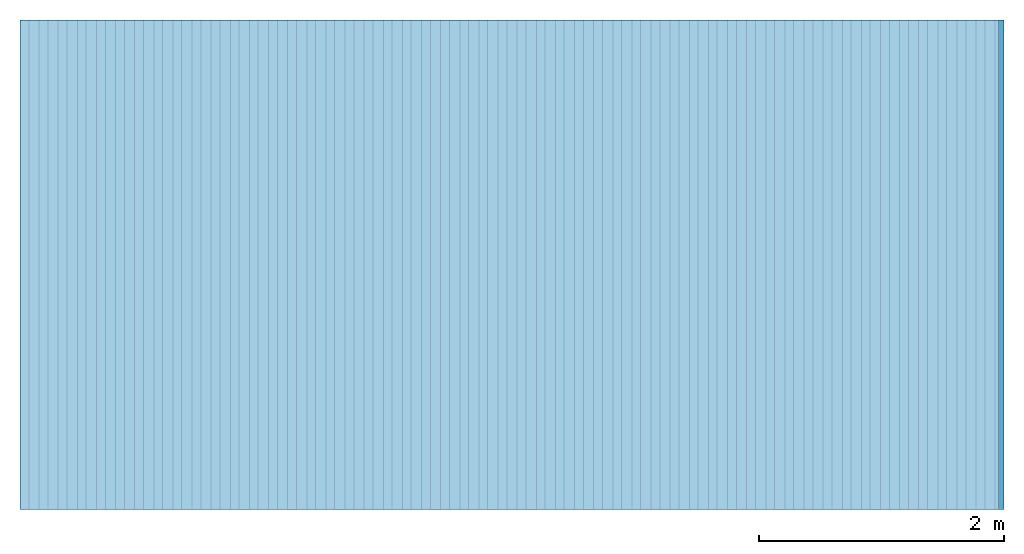
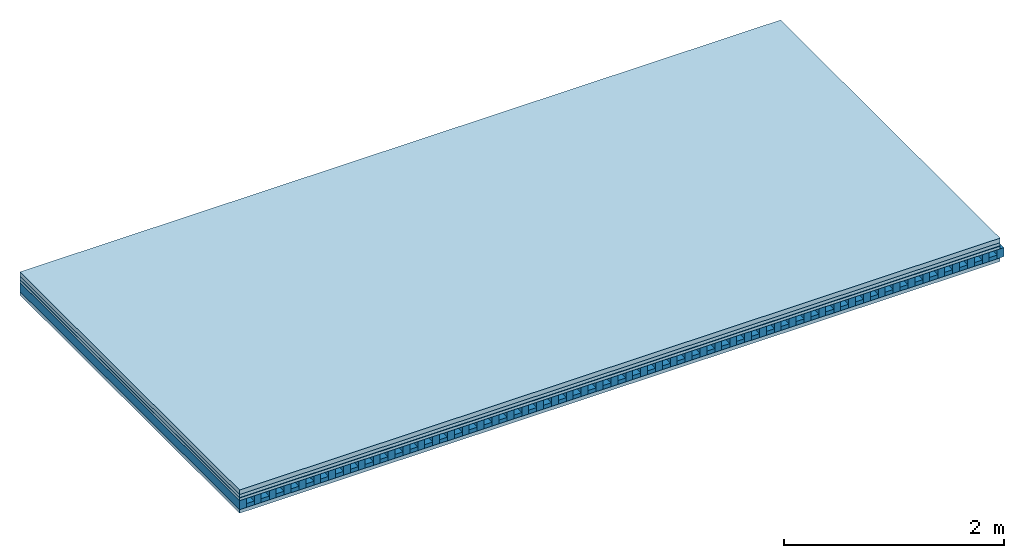
# One storey: 5 plates, 2 members, 1 element without a shape of its own.
"""IFC4 building model written with IfcOpenShell, lengths in metres."""

from ifc_helpers import new_model, si_unit, derived_unit, direction, frame, frame_2d, origin, origin_with_axes, place, context, project, spatial, rectangle, extrude, material, layer, layer_set, type_object, element, aggregate, save


model = new_model("IFC4")

# Units and contexts
plan_context = context("Plan", 3, precision=1e-05, world=origin(), true_north=direction((0.0, 1.0)))
model_context = context("Model", 3, precision=1e-05, world=origin(), true_north=direction((0.0, 1.0)))
ifc_project = project(units=[si_unit("LENGTHUNIT", "METRE"), derived_unit("SOUNDPRESSUREUNIT", [(si_unit("PRESSUREUNIT", "PASCAL", prefix="MICRO"), 0)]), si_unit("ENERGYUNIT", "JOULE", prefix="MEGA"), si_unit("MASSUNIT", "GRAM", prefix="KILO"), derived_unit("THERMALTRANSMITTANCEUNIT", [(si_unit("POWERUNIT", "WATT"), 1), (si_unit("AREAUNIT", "SQUARE_METRE"), -1), (si_unit("THERMODYNAMICTEMPERATUREUNIT", "KELVIN"), -1)]), derived_unit("AREADENSITYUNIT", [(si_unit("MASSUNIT", "GRAM", prefix="KILO"), 1), (si_unit("AREAUNIT", "SQUARE_METRE"), -1)]), derived_unit("USERDEFINED", [(si_unit("ENERGYUNIT", "JOULE", prefix="MEGA"), 1), (si_unit("AREAUNIT", "SQUARE_METRE"), -1)])], contexts=[plan_context, model_context])

# Site, building, storey
site = spatial("IfcSite", under=ifc_project)
building_placement = place(None, origin())
building = spatial("IfcBuilding", under=site, at=building_placement)
storey_placement = place(building_placement, origin())
storey = spatial("IfcBuildingStorey", under=building, at=storey_placement)

# Slab, members, plates
ifc_material_1 = material(Name="Cement screed", Category="04.006")
ifc_layer_1 = layer(ifc_material_1, 0.05, Name="On-material")
ifc_material_2 = material(Name="EP1, 35mm")
ifc_layer_2 = layer(ifc_material_2, 0.035, Name="Impact sound insulation")
ifc_material_3 = material(Name="Step 4mm", Category="10.009")
ifc_layer_3 = layer(ifc_material_3, 0.004, Name="Additional insulation")
ifc_material_4 = material()
ifc_layer_4 = layer(ifc_material_4, 0.03, Name="Sub-floor")
ifc_material_5 = material(Name="Rigid, of the art")
ifc_layer_5 = layer(ifc_material_5, 0.0, Name="Bond")
ifc_layer_6 = layer(None, 0.1, Name="Supporting structure")
ifc_layer_7 = layer(ifc_material_5, 0.0, Name="Bond")
ifc_material_6 = material(Name="panel on the underside HBF 40mm (20+20mm)", Category="07.001")
ifc_layer_8 = layer(ifc_material_6, 0.04, Name="Lower layer 1")
ifc_layer_set = layer_set([ifc_layer_1, ifc_layer_2, ifc_layer_3, ifc_layer_4, ifc_layer_5, ifc_layer_6, ifc_layer_7, ifc_layer_8])
slab_type = type_object("IfcSlabType", Name="A0086", PredefinedType="NOTDEFINED", material=ifc_layer_set)
slab_placement = place(None, frame((0.0, 0.0, 0.0), z_axis=(0.0, 0.0, -1.0), x_axis=(1.0, 0.0, 0.0)))
slab = element("IfcSlab", 1, at=slab_placement, inside=storey, type_object=slab_type, material=ifc_layer_set, Name="Slab #1")
ifc_material_7 = material(Name="Block Q4")
member_1_placement = place(slab_placement, origin())
member_1 = element("IfcMember", 2, at=member_1_placement, material=ifc_material_7, Name="Supporting structure", context=plan_context, shape_type="SweptSolid", body=[
    extrude(rectangle(XDim=0.071666666666667, YDim=0.1, at=frame_2d((0.0358333333333335, 0.05), x_axis=(1.0, 0.0))), frame((0.0, 4.0, 0.119), z_axis=(0.0, -1.0, 0.0), x_axis=(1.0, 0.0, 0.0)), (0.0, 0.0, 1.0), 4.0),
    extrude(rectangle(XDim=0.071666666666667, YDim=0.1, at=frame_2d((0.0358333333333335, 0.05), x_axis=(1.0, 0.0))), frame((0.15625, 4.0, 0.119), z_axis=(0.0, -1.0, 0.0), x_axis=(1.0, 0.0, 0.0)), (0.0, 0.0, 1.0), 4.0),
    extrude(rectangle(XDim=0.071666666666667, YDim=0.1, at=frame_2d((0.0358333333333335, 0.05), x_axis=(1.0, 0.0))), frame((0.3125, 4.0, 0.119), z_axis=(0.0, -1.0, 0.0), x_axis=(1.0, 0.0, 0.0)), (0.0, 0.0, 1.0), 4.0),
    extrude(rectangle(XDim=0.071666666666667, YDim=0.1, at=frame_2d((0.0358333333333335, 0.05), x_axis=(1.0, 0.0))), frame((0.46875, 4.0, 0.119), z_axis=(0.0, -1.0, 0.0), x_axis=(1.0, 0.0, 0.0)), (0.0, 0.0, 1.0), 4.0),
    extrude(rectangle(XDim=0.071666666666667, YDim=0.1, at=frame_2d((0.0358333333333335, 0.05), x_axis=(1.0, 0.0))), frame((0.625, 4.0, 0.119), z_axis=(0.0, -1.0, 0.0), x_axis=(1.0, 0.0, 0.0)), (0.0, 0.0, 1.0), 4.0),
    extrude(rectangle(XDim=0.071666666666667, YDim=0.1, at=frame_2d((0.0358333333333335, 0.05), x_axis=(1.0, 0.0))), frame((0.78125, 4.0, 0.119), z_axis=(0.0, -1.0, 0.0), x_axis=(1.0, 0.0, 0.0)), (0.0, 0.0, 1.0), 4.0),
    extrude(rectangle(XDim=0.071666666666667, YDim=0.1, at=frame_2d((0.0358333333333335, 0.05), x_axis=(1.0, 0.0))), frame((0.9375, 4.0, 0.119), z_axis=(0.0, -1.0, 0.0), x_axis=(1.0, 0.0, 0.0)), (0.0, 0.0, 1.0), 4.0),
    extrude(rectangle(XDim=0.071666666666667, YDim=0.1, at=frame_2d((0.0358333333333335, 0.05), x_axis=(1.0, 0.0))), frame((1.09375, 4.0, 0.119), z_axis=(0.0, -1.0, 0.0), x_axis=(1.0, 0.0, 0.0)), (0.0, 0.0, 1.0), 4.0),
    extrude(rectangle(XDim=0.071666666666667, YDim=0.1, at=frame_2d((0.0358333333333335, 0.05), x_axis=(1.0, 0.0))), frame((1.25, 4.0, 0.119), z_axis=(0.0, -1.0, 0.0), x_axis=(1.0, 0.0, 0.0)), (0.0, 0.0, 1.0), 4.0),
    extrude(rectangle(XDim=0.071666666666667, YDim=0.1, at=frame_2d((0.0358333333333335, 0.05), x_axis=(1.0, 0.0))), frame((1.40625, 4.0, 0.119), z_axis=(0.0, -1.0, 0.0), x_axis=(1.0, 0.0, 0.0)), (0.0, 0.0, 1.0), 4.0),
    extrude(rectangle(XDim=0.071666666666667, YDim=0.1, at=frame_2d((0.0358333333333335, 0.05), x_axis=(1.0, 0.0))), frame((1.5625, 4.0, 0.119), z_axis=(0.0, -1.0, 0.0), x_axis=(1.0, 0.0, 0.0)), (0.0, 0.0, 1.0), 4.0),
    extrude(rectangle(XDim=0.071666666666667, YDim=0.1, at=frame_2d((0.0358333333333335, 0.05), x_axis=(1.0, 0.0))), frame((1.71875, 4.0, 0.119), z_axis=(0.0, -1.0, 0.0), x_axis=(1.0, 0.0, 0.0)), (0.0, 0.0, 1.0), 4.0),
    extrude(rectangle(XDim=0.071666666666667, YDim=0.1, at=frame_2d((0.0358333333333335, 0.05), x_axis=(1.0, 0.0))), frame((1.875, 4.0, 0.119), z_axis=(0.0, -1.0, 0.0), x_axis=(1.0, 0.0, 0.0)), (0.0, 0.0, 1.0), 4.0),
    extrude(rectangle(XDim=0.071666666666667, YDim=0.1, at=frame_2d((0.0358333333333335, 0.05), x_axis=(1.0, 0.0))), frame((2.03125, 4.0, 0.119), z_axis=(0.0, -1.0, 0.0), x_axis=(1.0, 0.0, 0.0)), (0.0, 0.0, 1.0), 4.0),
    extrude(rectangle(XDim=0.071666666666667, YDim=0.1, at=frame_2d((0.0358333333333335, 0.05), x_axis=(1.0, 0.0))), frame((2.1875, 4.0, 0.119), z_axis=(0.0, -1.0, 0.0), x_axis=(1.0, 0.0, 0.0)), (0.0, 0.0, 1.0), 4.0),
    extrude(rectangle(XDim=0.071666666666667, YDim=0.1, at=frame_2d((0.0358333333333335, 0.05), x_axis=(1.0, 0.0))), frame((2.34375, 4.0, 0.119), z_axis=(0.0, -1.0, 0.0), x_axis=(1.0, 0.0, 0.0)), (0.0, 0.0, 1.0), 4.0),
    extrude(rectangle(XDim=0.071666666666667, YDim=0.1, at=frame_2d((0.0358333333333335, 0.05), x_axis=(1.0, 0.0))), frame((2.5, 4.0, 0.119), z_axis=(0.0, -1.0, 0.0), x_axis=(1.0, 0.0, 0.0)), (0.0, 0.0, 1.0), 4.0),
    extrude(rectangle(XDim=0.071666666666667, YDim=0.1, at=frame_2d((0.0358333333333335, 0.05), x_axis=(1.0, 0.0))), frame((2.65625, 4.0, 0.119), z_axis=(0.0, -1.0, 0.0), x_axis=(1.0, 0.0, 0.0)), (0.0, 0.0, 1.0), 4.0),
    extrude(rectangle(XDim=0.071666666666667, YDim=0.1, at=frame_2d((0.0358333333333335, 0.05), x_axis=(1.0, 0.0))), frame((2.8125, 4.0, 0.119), z_axis=(0.0, -1.0, 0.0), x_axis=(1.0, 0.0, 0.0)), (0.0, 0.0, 1.0), 4.0),
    extrude(rectangle(XDim=0.071666666666667, YDim=0.1, at=frame_2d((0.0358333333333335, 0.05), x_axis=(1.0, 0.0))), frame((2.96875, 4.0, 0.119), z_axis=(0.0, -1.0, 0.0), x_axis=(1.0, 0.0, 0.0)), (0.0, 0.0, 1.0), 4.0),
    extrude(rectangle(XDim=0.071666666666667, YDim=0.1, at=frame_2d((0.0358333333333335, 0.05), x_axis=(1.0, 0.0))), frame((3.125, 4.0, 0.119), z_axis=(0.0, -1.0, 0.0), x_axis=(1.0, 0.0, 0.0)), (0.0, 0.0, 1.0), 4.0),
    extrude(rectangle(XDim=0.071666666666667, YDim=0.1, at=frame_2d((0.0358333333333335, 0.05), x_axis=(1.0, 0.0))), frame((3.28125, 4.0, 0.119), z_axis=(0.0, -1.0, 0.0), x_axis=(1.0, 0.0, 0.0)), (0.0, 0.0, 1.0), 4.0),
    extrude(rectangle(XDim=0.071666666666667, YDim=0.1, at=frame_2d((0.0358333333333335, 0.05), x_axis=(1.0, 0.0))), frame((3.4375, 4.0, 0.119), z_axis=(0.0, -1.0, 0.0), x_axis=(1.0, 0.0, 0.0)), (0.0, 0.0, 1.0), 4.0),
    extrude(rectangle(XDim=0.071666666666667, YDim=0.1, at=frame_2d((0.0358333333333335, 0.05), x_axis=(1.0, 0.0))), frame((3.59375, 4.0, 0.119), z_axis=(0.0, -1.0, 0.0), x_axis=(1.0, 0.0, 0.0)), (0.0, 0.0, 1.0), 4.0),
    extrude(rectangle(XDim=0.071666666666667, YDim=0.1, at=frame_2d((0.0358333333333335, 0.05), x_axis=(1.0, 0.0))), frame((3.75, 4.0, 0.119), z_axis=(0.0, -1.0, 0.0), x_axis=(1.0, 0.0, 0.0)), (0.0, 0.0, 1.0), 4.0),
    extrude(rectangle(XDim=0.071666666666667, YDim=0.1, at=frame_2d((0.0358333333333335, 0.05), x_axis=(1.0, 0.0))), frame((3.90625, 4.0, 0.119), z_axis=(0.0, -1.0, 0.0), x_axis=(1.0, 0.0, 0.0)), (0.0, 0.0, 1.0), 4.0),
    extrude(rectangle(XDim=0.071666666666667, YDim=0.1, at=frame_2d((0.0358333333333335, 0.05), x_axis=(1.0, 0.0))), frame((4.0625, 4.0, 0.119), z_axis=(0.0, -1.0, 0.0), x_axis=(1.0, 0.0, 0.0)), (0.0, 0.0, 1.0), 4.0),
    extrude(rectangle(XDim=0.071666666666667, YDim=0.1, at=frame_2d((0.0358333333333335, 0.05), x_axis=(1.0, 0.0))), frame((4.21875, 4.0, 0.119), z_axis=(0.0, -1.0, 0.0), x_axis=(1.0, 0.0, 0.0)), (0.0, 0.0, 1.0), 4.0),
    extrude(rectangle(XDim=0.071666666666667, YDim=0.1, at=frame_2d((0.0358333333333335, 0.05), x_axis=(1.0, 0.0))), frame((4.375, 4.0, 0.119), z_axis=(0.0, -1.0, 0.0), x_axis=(1.0, 0.0, 0.0)), (0.0, 0.0, 1.0), 4.0),
    extrude(rectangle(XDim=0.071666666666667, YDim=0.1, at=frame_2d((0.0358333333333335, 0.05), x_axis=(1.0, 0.0))), frame((4.53125, 4.0, 0.119), z_axis=(0.0, -1.0, 0.0), x_axis=(1.0, 0.0, 0.0)), (0.0, 0.0, 1.0), 4.0),
    extrude(rectangle(XDim=0.071666666666667, YDim=0.1, at=frame_2d((0.0358333333333335, 0.05), x_axis=(1.0, 0.0))), frame((4.6875, 4.0, 0.119), z_axis=(0.0, -1.0, 0.0), x_axis=(1.0, 0.0, 0.0)), (0.0, 0.0, 1.0), 4.0),
    extrude(rectangle(XDim=0.071666666666667, YDim=0.1, at=frame_2d((0.0358333333333335, 0.05), x_axis=(1.0, 0.0))), frame((4.84375, 4.0, 0.119), z_axis=(0.0, -1.0, 0.0), x_axis=(1.0, 0.0, 0.0)), (0.0, 0.0, 1.0), 4.0),
    extrude(rectangle(XDim=0.071666666666667, YDim=0.1, at=frame_2d((0.0358333333333335, 0.05), x_axis=(1.0, 0.0))), frame((5.0, 4.0, 0.119), z_axis=(0.0, -1.0, 0.0), x_axis=(1.0, 0.0, 0.0)), (0.0, 0.0, 1.0), 4.0),
    extrude(rectangle(XDim=0.071666666666667, YDim=0.1, at=frame_2d((0.0358333333333335, 0.05), x_axis=(1.0, 0.0))), frame((5.15625, 4.0, 0.119), z_axis=(0.0, -1.0, 0.0), x_axis=(1.0, 0.0, 0.0)), (0.0, 0.0, 1.0), 4.0),
    extrude(rectangle(XDim=0.071666666666667, YDim=0.1, at=frame_2d((0.0358333333333335, 0.05), x_axis=(1.0, 0.0))), frame((5.3125, 4.0, 0.119), z_axis=(0.0, -1.0, 0.0), x_axis=(1.0, 0.0, 0.0)), (0.0, 0.0, 1.0), 4.0),
    extrude(rectangle(XDim=0.071666666666667, YDim=0.1, at=frame_2d((0.0358333333333335, 0.05), x_axis=(1.0, 0.0))), frame((5.46875, 4.0, 0.119), z_axis=(0.0, -1.0, 0.0), x_axis=(1.0, 0.0, 0.0)), (0.0, 0.0, 1.0), 4.0),
    extrude(rectangle(XDim=0.071666666666667, YDim=0.1, at=frame_2d((0.0358333333333335, 0.05), x_axis=(1.0, 0.0))), frame((5.625, 4.0, 0.119), z_axis=(0.0, -1.0, 0.0), x_axis=(1.0, 0.0, 0.0)), (0.0, 0.0, 1.0), 4.0),
    extrude(rectangle(XDim=0.071666666666667, YDim=0.1, at=frame_2d((0.0358333333333335, 0.05), x_axis=(1.0, 0.0))), frame((5.78125, 4.0, 0.119), z_axis=(0.0, -1.0, 0.0), x_axis=(1.0, 0.0, 0.0)), (0.0, 0.0, 1.0), 4.0),
    extrude(rectangle(XDim=0.071666666666667, YDim=0.1, at=frame_2d((0.0358333333333335, 0.05), x_axis=(1.0, 0.0))), frame((5.9375, 4.0, 0.119), z_axis=(0.0, -1.0, 0.0), x_axis=(1.0, 0.0, 0.0)), (0.0, 0.0, 1.0), 4.0),
    extrude(rectangle(XDim=0.071666666666667, YDim=0.1, at=frame_2d((0.0358333333333335, 0.05), x_axis=(1.0, 0.0))), frame((6.09375, 4.0, 0.119), z_axis=(0.0, -1.0, 0.0), x_axis=(1.0, 0.0, 0.0)), (0.0, 0.0, 1.0), 4.0),
    extrude(rectangle(XDim=0.071666666666667, YDim=0.1, at=frame_2d((0.0358333333333335, 0.05), x_axis=(1.0, 0.0))), frame((6.25, 4.0, 0.119), z_axis=(0.0, -1.0, 0.0), x_axis=(1.0, 0.0, 0.0)), (0.0, 0.0, 1.0), 4.0),
    extrude(rectangle(XDim=0.071666666666667, YDim=0.1, at=frame_2d((0.0358333333333335, 0.05), x_axis=(1.0, 0.0))), frame((6.40625, 4.0, 0.119), z_axis=(0.0, -1.0, 0.0), x_axis=(1.0, 0.0, 0.0)), (0.0, 0.0, 1.0), 4.0),
    extrude(rectangle(XDim=0.071666666666667, YDim=0.1, at=frame_2d((0.0358333333333335, 0.05), x_axis=(1.0, 0.0))), frame((6.5625, 4.0, 0.119), z_axis=(0.0, -1.0, 0.0), x_axis=(1.0, 0.0, 0.0)), (0.0, 0.0, 1.0), 4.0),
    extrude(rectangle(XDim=0.071666666666667, YDim=0.1, at=frame_2d((0.0358333333333335, 0.05), x_axis=(1.0, 0.0))), frame((6.71875, 4.0, 0.119), z_axis=(0.0, -1.0, 0.0), x_axis=(1.0, 0.0, 0.0)), (0.0, 0.0, 1.0), 4.0),
    extrude(rectangle(XDim=0.071666666666667, YDim=0.1, at=frame_2d((0.0358333333333335, 0.05), x_axis=(1.0, 0.0))), frame((6.875, 4.0, 0.119), z_axis=(0.0, -1.0, 0.0), x_axis=(1.0, 0.0, 0.0)), (0.0, 0.0, 1.0), 4.0),
    extrude(rectangle(XDim=0.071666666666667, YDim=0.1, at=frame_2d((0.0358333333333335, 0.05), x_axis=(1.0, 0.0))), frame((7.03125, 4.0, 0.119), z_axis=(0.0, -1.0, 0.0), x_axis=(1.0, 0.0, 0.0)), (0.0, 0.0, 1.0), 4.0),
    extrude(rectangle(XDim=0.071666666666667, YDim=0.1, at=frame_2d((0.0358333333333335, 0.05), x_axis=(1.0, 0.0))), frame((7.1875, 4.0, 0.119), z_axis=(0.0, -1.0, 0.0), x_axis=(1.0, 0.0, 0.0)), (0.0, 0.0, 1.0), 4.0),
    extrude(rectangle(XDim=0.071666666666667, YDim=0.1, at=frame_2d((0.0358333333333335, 0.05), x_axis=(1.0, 0.0))), frame((7.34375, 4.0, 0.119), z_axis=(0.0, -1.0, 0.0), x_axis=(1.0, 0.0, 0.0)), (0.0, 0.0, 1.0), 4.0),
    extrude(rectangle(XDim=0.071666666666667, YDim=0.1, at=frame_2d((0.0358333333333335, 0.05), x_axis=(1.0, 0.0))), frame((7.5, 4.0, 0.119), z_axis=(0.0, -1.0, 0.0), x_axis=(1.0, 0.0, 0.0)), (0.0, 0.0, 1.0), 4.0),
    extrude(rectangle(XDim=0.071666666666667, YDim=0.1, at=frame_2d((0.0358333333333335, 0.05), x_axis=(1.0, 0.0))), frame((7.65625, 4.0, 0.119), z_axis=(0.0, -1.0, 0.0), x_axis=(1.0, 0.0, 0.0)), (0.0, 0.0, 1.0), 4.0),
    extrude(rectangle(XDim=0.071666666666667, YDim=0.1, at=frame_2d((0.0358333333333335, 0.05), x_axis=(1.0, 0.0))), frame((7.8125, 4.0, 0.119), z_axis=(0.0, -1.0, 0.0), x_axis=(1.0, 0.0, 0.0)), (0.0, 0.0, 1.0), 4.0),
    extrude(rectangle(XDim=0.071666666666667, YDim=0.1, at=frame_2d((0.0358333333333335, 0.05), x_axis=(1.0, 0.0))), frame((7.96875, 4.0, 0.119), z_axis=(0.0, -1.0, 0.0), x_axis=(1.0, 0.0, 0.0)), (0.0, 0.0, 1.0), 4.0),
])
ifc_material_8 = material()
member_2_placement = place(slab_placement, origin())
member_2 = element("IfcMember", 3, at=member_2_placement, material=ifc_material_8, Name="in supporting structure", context=plan_context, shape_type="SweptSolid", body=[
    extrude(rectangle(XDim=0.084583333333333, YDim=0.042, at=frame_2d((0.0422916666666665, 0.021), x_axis=(1.0, 0.0))), frame((0.071666666666667, 4.0, 0.177), z_axis=(0.0, -1.0, 0.0), x_axis=(1.0, 0.0, 0.0)), (0.0, 0.0, 1.0), 4.0),
    extrude(rectangle(XDim=0.084583333333333, YDim=0.042, at=frame_2d((0.0422916666666665, 0.021), x_axis=(1.0, 0.0))), frame((0.227916666666667, 4.0, 0.177), z_axis=(0.0, -1.0, 0.0), x_axis=(1.0, 0.0, 0.0)), (0.0, 0.0, 1.0), 4.0),
    extrude(rectangle(XDim=0.084583333333333, YDim=0.042, at=frame_2d((0.0422916666666665, 0.021), x_axis=(1.0, 0.0))), frame((0.384166666666667, 4.0, 0.177), z_axis=(0.0, -1.0, 0.0), x_axis=(1.0, 0.0, 0.0)), (0.0, 0.0, 1.0), 4.0),
    extrude(rectangle(XDim=0.084583333333333, YDim=0.042, at=frame_2d((0.0422916666666665, 0.021), x_axis=(1.0, 0.0))), frame((0.540416666666667, 4.0, 0.177), z_axis=(0.0, -1.0, 0.0), x_axis=(1.0, 0.0, 0.0)), (0.0, 0.0, 1.0), 4.0),
    extrude(rectangle(XDim=0.084583333333333, YDim=0.042, at=frame_2d((0.0422916666666665, 0.021), x_axis=(1.0, 0.0))), frame((0.696666666666667, 4.0, 0.177), z_axis=(0.0, -1.0, 0.0), x_axis=(1.0, 0.0, 0.0)), (0.0, 0.0, 1.0), 4.0),
    extrude(rectangle(XDim=0.084583333333333, YDim=0.042, at=frame_2d((0.0422916666666665, 0.021), x_axis=(1.0, 0.0))), frame((0.852916666666667, 4.0, 0.177), z_axis=(0.0, -1.0, 0.0), x_axis=(1.0, 0.0, 0.0)), (0.0, 0.0, 1.0), 4.0),
    extrude(rectangle(XDim=0.084583333333333, YDim=0.042, at=frame_2d((0.0422916666666665, 0.021), x_axis=(1.0, 0.0))), frame((1.00916666666667, 4.0, 0.177), z_axis=(0.0, -1.0, 0.0), x_axis=(1.0, 0.0, 0.0)), (0.0, 0.0, 1.0), 4.0),
    extrude(rectangle(XDim=0.084583333333333, YDim=0.042, at=frame_2d((0.0422916666666665, 0.021), x_axis=(1.0, 0.0))), frame((1.16541666666667, 4.0, 0.177), z_axis=(0.0, -1.0, 0.0), x_axis=(1.0, 0.0, 0.0)), (0.0, 0.0, 1.0), 4.0),
    extrude(rectangle(XDim=0.084583333333333, YDim=0.042, at=frame_2d((0.0422916666666665, 0.021), x_axis=(1.0, 0.0))), frame((1.32166666666667, 4.0, 0.177), z_axis=(0.0, -1.0, 0.0), x_axis=(1.0, 0.0, 0.0)), (0.0, 0.0, 1.0), 4.0),
    extrude(rectangle(XDim=0.084583333333333, YDim=0.042, at=frame_2d((0.0422916666666665, 0.021), x_axis=(1.0, 0.0))), frame((1.47791666666667, 4.0, 0.177), z_axis=(0.0, -1.0, 0.0), x_axis=(1.0, 0.0, 0.0)), (0.0, 0.0, 1.0), 4.0),
    extrude(rectangle(XDim=0.084583333333333, YDim=0.042, at=frame_2d((0.0422916666666665, 0.021), x_axis=(1.0, 0.0))), frame((1.63416666666667, 4.0, 0.177), z_axis=(0.0, -1.0, 0.0), x_axis=(1.0, 0.0, 0.0)), (0.0, 0.0, 1.0), 4.0),
    extrude(rectangle(XDim=0.084583333333333, YDim=0.042, at=frame_2d((0.0422916666666665, 0.021), x_axis=(1.0, 0.0))), frame((1.79041666666667, 4.0, 0.177), z_axis=(0.0, -1.0, 0.0), x_axis=(1.0, 0.0, 0.0)), (0.0, 0.0, 1.0), 4.0),
    extrude(rectangle(XDim=0.084583333333333, YDim=0.042, at=frame_2d((0.0422916666666665, 0.021), x_axis=(1.0, 0.0))), frame((1.94666666666667, 4.0, 0.177), z_axis=(0.0, -1.0, 0.0), x_axis=(1.0, 0.0, 0.0)), (0.0, 0.0, 1.0), 4.0),
    extrude(rectangle(XDim=0.084583333333333, YDim=0.042, at=frame_2d((0.0422916666666665, 0.021), x_axis=(1.0, 0.0))), frame((2.10291666666667, 4.0, 0.177), z_axis=(0.0, -1.0, 0.0), x_axis=(1.0, 0.0, 0.0)), (0.0, 0.0, 1.0), 4.0),
    extrude(rectangle(XDim=0.084583333333333, YDim=0.042, at=frame_2d((0.0422916666666665, 0.021), x_axis=(1.0, 0.0))), frame((2.25916666666667, 4.0, 0.177), z_axis=(0.0, -1.0, 0.0), x_axis=(1.0, 0.0, 0.0)), (0.0, 0.0, 1.0), 4.0),
    extrude(rectangle(XDim=0.084583333333333, YDim=0.042, at=frame_2d((0.0422916666666665, 0.021), x_axis=(1.0, 0.0))), frame((2.41541666666667, 4.0, 0.177), z_axis=(0.0, -1.0, 0.0), x_axis=(1.0, 0.0, 0.0)), (0.0, 0.0, 1.0), 4.0),
    extrude(rectangle(XDim=0.084583333333333, YDim=0.042, at=frame_2d((0.0422916666666665, 0.021), x_axis=(1.0, 0.0))), frame((2.57166666666667, 4.0, 0.177), z_axis=(0.0, -1.0, 0.0), x_axis=(1.0, 0.0, 0.0)), (0.0, 0.0, 1.0), 4.0),
    extrude(rectangle(XDim=0.084583333333333, YDim=0.042, at=frame_2d((0.0422916666666665, 0.021), x_axis=(1.0, 0.0))), frame((2.72791666666667, 4.0, 0.177), z_axis=(0.0, -1.0, 0.0), x_axis=(1.0, 0.0, 0.0)), (0.0, 0.0, 1.0), 4.0),
    extrude(rectangle(XDim=0.084583333333333, YDim=0.042, at=frame_2d((0.0422916666666665, 0.021), x_axis=(1.0, 0.0))), frame((2.88416666666667, 4.0, 0.177), z_axis=(0.0, -1.0, 0.0), x_axis=(1.0, 0.0, 0.0)), (0.0, 0.0, 1.0), 4.0),
    extrude(rectangle(XDim=0.084583333333333, YDim=0.042, at=frame_2d((0.0422916666666665, 0.021), x_axis=(1.0, 0.0))), frame((3.04041666666667, 4.0, 0.177), z_axis=(0.0, -1.0, 0.0), x_axis=(1.0, 0.0, 0.0)), (0.0, 0.0, 1.0), 4.0),
    extrude(rectangle(XDim=0.084583333333333, YDim=0.042, at=frame_2d((0.0422916666666665, 0.021), x_axis=(1.0, 0.0))), frame((3.19666666666667, 4.0, 0.177), z_axis=(0.0, -1.0, 0.0), x_axis=(1.0, 0.0, 0.0)), (0.0, 0.0, 1.0), 4.0),
    extrude(rectangle(XDim=0.084583333333333, YDim=0.042, at=frame_2d((0.0422916666666665, 0.021), x_axis=(1.0, 0.0))), frame((3.35291666666667, 4.0, 0.177), z_axis=(0.0, -1.0, 0.0), x_axis=(1.0, 0.0, 0.0)), (0.0, 0.0, 1.0), 4.0),
    extrude(rectangle(XDim=0.084583333333333, YDim=0.042, at=frame_2d((0.0422916666666665, 0.021), x_axis=(1.0, 0.0))), frame((3.50916666666667, 4.0, 0.177), z_axis=(0.0, -1.0, 0.0), x_axis=(1.0, 0.0, 0.0)), (0.0, 0.0, 1.0), 4.0),
    extrude(rectangle(XDim=0.084583333333333, YDim=0.042, at=frame_2d((0.0422916666666665, 0.021), x_axis=(1.0, 0.0))), frame((3.66541666666667, 4.0, 0.177), z_axis=(0.0, -1.0, 0.0), x_axis=(1.0, 0.0, 0.0)), (0.0, 0.0, 1.0), 4.0),
    extrude(rectangle(XDim=0.084583333333333, YDim=0.042, at=frame_2d((0.0422916666666665, 0.021), x_axis=(1.0, 0.0))), frame((3.82166666666667, 4.0, 0.177), z_axis=(0.0, -1.0, 0.0), x_axis=(1.0, 0.0, 0.0)), (0.0, 0.0, 1.0), 4.0),
    extrude(rectangle(XDim=0.084583333333333, YDim=0.042, at=frame_2d((0.0422916666666665, 0.021), x_axis=(1.0, 0.0))), frame((3.97791666666667, 4.0, 0.177), z_axis=(0.0, -1.0, 0.0), x_axis=(1.0, 0.0, 0.0)), (0.0, 0.0, 1.0), 4.0),
    extrude(rectangle(XDim=0.084583333333333, YDim=0.042, at=frame_2d((0.0422916666666665, 0.021), x_axis=(1.0, 0.0))), frame((4.13416666666667, 4.0, 0.177), z_axis=(0.0, -1.0, 0.0), x_axis=(1.0, 0.0, 0.0)), (0.0, 0.0, 1.0), 4.0),
    extrude(rectangle(XDim=0.084583333333333, YDim=0.042, at=frame_2d((0.0422916666666665, 0.021), x_axis=(1.0, 0.0))), frame((4.29041666666667, 4.0, 0.177), z_axis=(0.0, -1.0, 0.0), x_axis=(1.0, 0.0, 0.0)), (0.0, 0.0, 1.0), 4.0),
    extrude(rectangle(XDim=0.084583333333333, YDim=0.042, at=frame_2d((0.0422916666666665, 0.021), x_axis=(1.0, 0.0))), frame((4.44666666666667, 4.0, 0.177), z_axis=(0.0, -1.0, 0.0), x_axis=(1.0, 0.0, 0.0)), (0.0, 0.0, 1.0), 4.0),
    extrude(rectangle(XDim=0.084583333333333, YDim=0.042, at=frame_2d((0.0422916666666665, 0.021), x_axis=(1.0, 0.0))), frame((4.60291666666667, 4.0, 0.177), z_axis=(0.0, -1.0, 0.0), x_axis=(1.0, 0.0, 0.0)), (0.0, 0.0, 1.0), 4.0),
    extrude(rectangle(XDim=0.084583333333333, YDim=0.042, at=frame_2d((0.0422916666666665, 0.021), x_axis=(1.0, 0.0))), frame((4.75916666666667, 4.0, 0.177), z_axis=(0.0, -1.0, 0.0), x_axis=(1.0, 0.0, 0.0)), (0.0, 0.0, 1.0), 4.0),
    extrude(rectangle(XDim=0.084583333333333, YDim=0.042, at=frame_2d((0.0422916666666665, 0.021), x_axis=(1.0, 0.0))), frame((4.91541666666667, 4.0, 0.177), z_axis=(0.0, -1.0, 0.0), x_axis=(1.0, 0.0, 0.0)), (0.0, 0.0, 1.0), 4.0),
    extrude(rectangle(XDim=0.084583333333333, YDim=0.042, at=frame_2d((0.0422916666666665, 0.021), x_axis=(1.0, 0.0))), frame((5.07166666666667, 4.0, 0.177), z_axis=(0.0, -1.0, 0.0), x_axis=(1.0, 0.0, 0.0)), (0.0, 0.0, 1.0), 4.0),
    extrude(rectangle(XDim=0.084583333333333, YDim=0.042, at=frame_2d((0.0422916666666665, 0.021), x_axis=(1.0, 0.0))), frame((5.22791666666667, 4.0, 0.177), z_axis=(0.0, -1.0, 0.0), x_axis=(1.0, 0.0, 0.0)), (0.0, 0.0, 1.0), 4.0),
    extrude(rectangle(XDim=0.084583333333333, YDim=0.042, at=frame_2d((0.0422916666666665, 0.021), x_axis=(1.0, 0.0))), frame((5.38416666666667, 4.0, 0.177), z_axis=(0.0, -1.0, 0.0), x_axis=(1.0, 0.0, 0.0)), (0.0, 0.0, 1.0), 4.0),
    extrude(rectangle(XDim=0.084583333333333, YDim=0.042, at=frame_2d((0.0422916666666665, 0.021), x_axis=(1.0, 0.0))), frame((5.54041666666667, 4.0, 0.177), z_axis=(0.0, -1.0, 0.0), x_axis=(1.0, 0.0, 0.0)), (0.0, 0.0, 1.0), 4.0),
    extrude(rectangle(XDim=0.084583333333333, YDim=0.042, at=frame_2d((0.0422916666666665, 0.021), x_axis=(1.0, 0.0))), frame((5.69666666666667, 4.0, 0.177), z_axis=(0.0, -1.0, 0.0), x_axis=(1.0, 0.0, 0.0)), (0.0, 0.0, 1.0), 4.0),
    extrude(rectangle(XDim=0.084583333333333, YDim=0.042, at=frame_2d((0.0422916666666665, 0.021), x_axis=(1.0, 0.0))), frame((5.85291666666667, 4.0, 0.177), z_axis=(0.0, -1.0, 0.0), x_axis=(1.0, 0.0, 0.0)), (0.0, 0.0, 1.0), 4.0),
    extrude(rectangle(XDim=0.084583333333333, YDim=0.042, at=frame_2d((0.0422916666666665, 0.021), x_axis=(1.0, 0.0))), frame((6.00916666666667, 4.0, 0.177), z_axis=(0.0, -1.0, 0.0), x_axis=(1.0, 0.0, 0.0)), (0.0, 0.0, 1.0), 4.0),
    extrude(rectangle(XDim=0.084583333333333, YDim=0.042, at=frame_2d((0.0422916666666665, 0.021), x_axis=(1.0, 0.0))), frame((6.16541666666667, 4.0, 0.177), z_axis=(0.0, -1.0, 0.0), x_axis=(1.0, 0.0, 0.0)), (0.0, 0.0, 1.0), 4.0),
    extrude(rectangle(XDim=0.084583333333333, YDim=0.042, at=frame_2d((0.0422916666666665, 0.021), x_axis=(1.0, 0.0))), frame((6.32166666666667, 4.0, 0.177), z_axis=(0.0, -1.0, 0.0), x_axis=(1.0, 0.0, 0.0)), (0.0, 0.0, 1.0), 4.0),
    extrude(rectangle(XDim=0.084583333333333, YDim=0.042, at=frame_2d((0.0422916666666665, 0.021), x_axis=(1.0, 0.0))), frame((6.47791666666667, 4.0, 0.177), z_axis=(0.0, -1.0, 0.0), x_axis=(1.0, 0.0, 0.0)), (0.0, 0.0, 1.0), 4.0),
    extrude(rectangle(XDim=0.084583333333333, YDim=0.042, at=frame_2d((0.0422916666666665, 0.021), x_axis=(1.0, 0.0))), frame((6.63416666666667, 4.0, 0.177), z_axis=(0.0, -1.0, 0.0), x_axis=(1.0, 0.0, 0.0)), (0.0, 0.0, 1.0), 4.0),
    extrude(rectangle(XDim=0.084583333333333, YDim=0.042, at=frame_2d((0.0422916666666665, 0.021), x_axis=(1.0, 0.0))), frame((6.79041666666667, 4.0, 0.177), z_axis=(0.0, -1.0, 0.0), x_axis=(1.0, 0.0, 0.0)), (0.0, 0.0, 1.0), 4.0),
    extrude(rectangle(XDim=0.084583333333333, YDim=0.042, at=frame_2d((0.0422916666666665, 0.021), x_axis=(1.0, 0.0))), frame((6.94666666666667, 4.0, 0.177), z_axis=(0.0, -1.0, 0.0), x_axis=(1.0, 0.0, 0.0)), (0.0, 0.0, 1.0), 4.0),
    extrude(rectangle(XDim=0.084583333333333, YDim=0.042, at=frame_2d((0.0422916666666665, 0.021), x_axis=(1.0, 0.0))), frame((7.10291666666667, 4.0, 0.177), z_axis=(0.0, -1.0, 0.0), x_axis=(1.0, 0.0, 0.0)), (0.0, 0.0, 1.0), 4.0),
    extrude(rectangle(XDim=0.084583333333333, YDim=0.042, at=frame_2d((0.0422916666666665, 0.021), x_axis=(1.0, 0.0))), frame((7.25916666666667, 4.0, 0.177), z_axis=(0.0, -1.0, 0.0), x_axis=(1.0, 0.0, 0.0)), (0.0, 0.0, 1.0), 4.0),
    extrude(rectangle(XDim=0.084583333333333, YDim=0.042, at=frame_2d((0.0422916666666665, 0.021), x_axis=(1.0, 0.0))), frame((7.41541666666667, 4.0, 0.177), z_axis=(0.0, -1.0, 0.0), x_axis=(1.0, 0.0, 0.0)), (0.0, 0.0, 1.0), 4.0),
    extrude(rectangle(XDim=0.084583333333333, YDim=0.042, at=frame_2d((0.0422916666666665, 0.021), x_axis=(1.0, 0.0))), frame((7.57166666666667, 4.0, 0.177), z_axis=(0.0, -1.0, 0.0), x_axis=(1.0, 0.0, 0.0)), (0.0, 0.0, 1.0), 4.0),
    extrude(rectangle(XDim=0.084583333333333, YDim=0.042, at=frame_2d((0.0422916666666665, 0.021), x_axis=(1.0, 0.0))), frame((7.72791666666667, 4.0, 0.177), z_axis=(0.0, -1.0, 0.0), x_axis=(1.0, 0.0, 0.0)), (0.0, 0.0, 1.0), 4.0),
    extrude(rectangle(XDim=0.084583333333333, YDim=0.042, at=frame_2d((0.0422916666666665, 0.021), x_axis=(1.0, 0.0))), frame((7.88416666666667, 4.0, 0.177), z_axis=(0.0, -1.0, 0.0), x_axis=(1.0, 0.0, 0.0)), (0.0, 0.0, 1.0), 4.0),
])
plate_1_placement = place(slab_placement, origin())
plate_1 = element("IfcPlate", 4, at=plate_1_placement, material=ifc_material_1, Name="On-material", context=plan_context, shape_type="SweptSolid", body=[
    extrude(rectangle(XDim=8.0, YDim=4.0, at=frame_2d((4.0, 2.0), x_axis=(1.0, 0.0))), origin_with_axes(), (0.0, 0.0, 1.0), 0.05),
])
plate_2_placement = place(slab_placement, origin())
plate_2 = element("IfcPlate", 5, at=plate_2_placement, material=ifc_material_2, Name="Impact sound insulation", context=plan_context, shape_type="SweptSolid", body=[
    extrude(rectangle(XDim=8.0, YDim=4.0, at=frame_2d((4.0, 2.0), x_axis=(1.0, 0.0))), frame((0.0, 0.0, 0.05), z_axis=(0.0, 0.0, 1.0), x_axis=(1.0, 0.0, 0.0)), (0.0, 0.0, 1.0), 0.035),
])
plate_3_placement = place(slab_placement, origin())
plate_3 = element("IfcPlate", 6, at=plate_3_placement, material=ifc_material_3, Name="Additional insulation", context=plan_context, shape_type="SweptSolid", body=[
    extrude(rectangle(XDim=8.0, YDim=4.0, at=frame_2d((4.0, 2.0), x_axis=(1.0, 0.0))), frame((0.0, 0.0, 0.085), z_axis=(0.0, 0.0, 1.0), x_axis=(1.0, 0.0, 0.0)), (0.0, 0.0, 1.0), 0.004),
])
plate_4_placement = place(slab_placement, origin())
plate_4 = element("IfcPlate", 7, at=plate_4_placement, material=ifc_material_4, Name="Sub-floor", context=plan_context, shape_type="SweptSolid", body=[
    extrude(rectangle(XDim=8.0, YDim=4.0, at=frame_2d((4.0, 2.0), x_axis=(1.0, 0.0))), frame((0.0, 0.0, 0.089), z_axis=(0.0, 0.0, 1.0), x_axis=(1.0, 0.0, 0.0)), (0.0, 0.0, 1.0), 0.03),
])
plate_5_placement = place(slab_placement, origin())
plate_5 = element("IfcPlate", 8, at=plate_5_placement, material=ifc_material_6, Name="Lower layer 1", context=plan_context, shape_type="SweptSolid", body=[
    extrude(rectangle(XDim=8.0, YDim=4.0, at=frame_2d((4.0, 2.0), x_axis=(1.0, 0.0))), frame((0.0, 0.0, 0.219), z_axis=(0.0, 0.0, 1.0), x_axis=(1.0, 0.0, 0.0)), (0.0, 0.0, 1.0), 0.04),
])
aggregate(slab, [plate_1, plate_2, plate_3, plate_4, member_1, member_2, plate_5])

save(model, "model.ifc")
